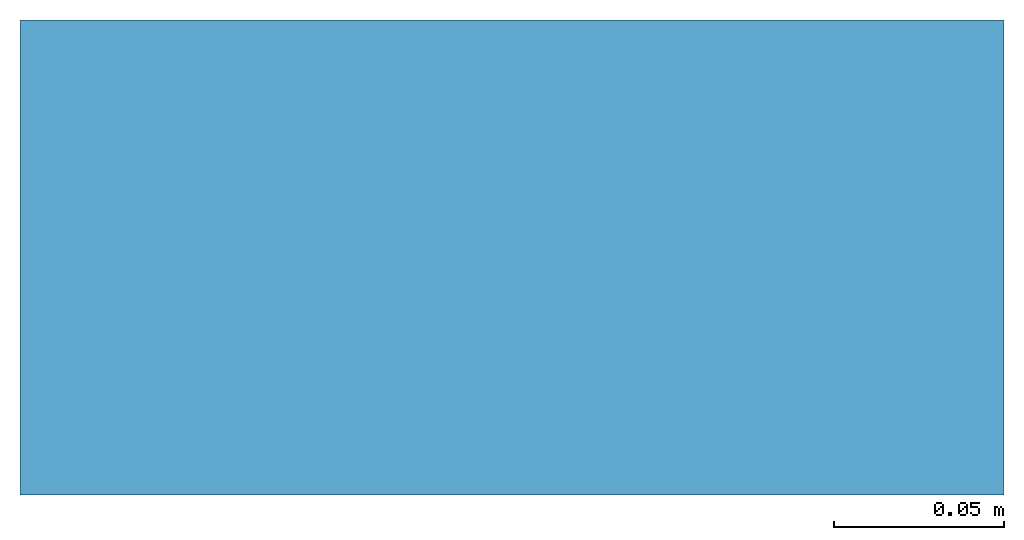
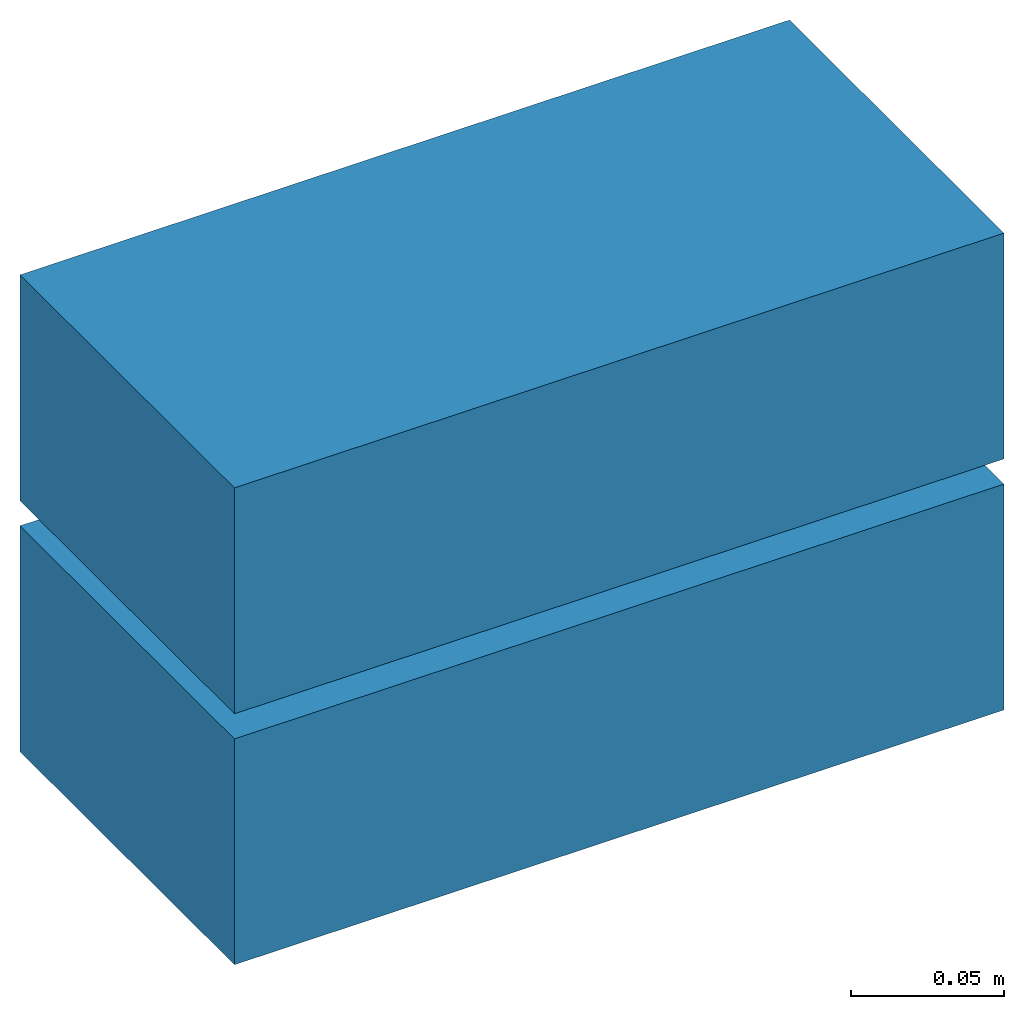
# One storey: 2 beams.
"""IFC4 building model written with IfcOpenShell, lengths in millimetres."""

from ifc_helpers import new_model, entity, si_unit, converted_unit, frame, origin_with_axes, origin_2d_with_axis, place, context, subcontext, project, spatial, polygons, source, transform, mapped, material, type_object, type_shapes, element, save


model = new_model("IFC4")

# Units and contexts
model_context = context("Model", 3, precision=1e-05, world=origin_with_axes())
plan_context = context("Plan", 2, precision=1e-05, world=origin_2d_with_axis())
body_context = subcontext(model_context, "Body", "Model", "MODEL_VIEW")
ifc_project = project(units=[si_unit("VOLUMEUNIT", "CUBIC_METRE"), si_unit("LENGTHUNIT", "METRE", prefix="MILLI"), converted_unit("PLANEANGLEUNIT", "degree", entity("IfcReal", 0.0174532925199433), si_unit("PLANEANGLEUNIT", "RADIAN"), dimensions=[0, 0, 0, 0, 0, 0, 0]), si_unit("AREAUNIT", "SQUARE_METRE")], contexts=[model_context, plan_context])

# Site, building, storey
site_placement = place(None, origin_with_axes())
site = spatial("IfcSite", under=ifc_project, at=site_placement)
building_placement = place(site_placement, origin_with_axes())
building = spatial("IfcBuilding", under=site, at=building_placement, Name="Building")
storey_placement = place(building_placement, origin_with_axes())
storey = spatial("IfcBuildingStorey", under=building, at=storey_placement, Name="Storey")

# Beams
ifc_material = material(Name="Cement Block", Category="Cement")
beam_type = type_object("IfcBeamType", Name="RDP 290x140x90", PredefinedType="USERDEFINED", material=ifc_material)
shared_shape = source(origin_with_axes(), body_context, "Body", "Tessellation", [
    polygons([(0.861823499202728, -0.0736117288470268, 0.359587341547012), (0.861823499202728, -0.0736117288470268, 90.3595581054688), (0.861823499202728, 139.926361083984, 0.359587341547012), (0.861823499202728, 139.926361083984, 90.3595581054688), (290.861755371094, -0.0736117288470268, 0.359587341547012), (290.861755371094, -0.0736117288470268, 90.3595581054688), (290.861755371094, 139.926361083984, 0.359587341547012), (290.861755371094, 139.926361083984, 90.3595581054688)], [[[1, 2, 4, 3]], [[3, 4, 8, 7]], [[7, 8, 6, 5]], [[5, 6, 2, 1]], [[3, 7, 5, 1]], [[8, 4, 2, 6]]], closed=True),
])
type_shapes(beam_type, [shared_shape])
beam_1_placement = place(storey_placement, frame((0.0, 0.0, 99.6404141187668), z_axis=(0.0, 0.0, 1.0), x_axis=(1.0, 0.0, 0.0)))
element("IfcBeam", 1, at=beam_1_placement, inside=storey, type_object=beam_type, Name="290x90x140", context=body_context, shape_type="MappedRepresentation", body=[
    mapped(shared_shape, transform((0.0, 0.0, 0.0), x_axis=(1.0, 0.0, 0.0), y_axis=(0.0, 1.0, 0.0), z_axis=(0.0, 0.0, 1.0), scale=1.0)),
])
beam_2_placement = place(storey_placement, frame((0.0, 0.0, -0.359587371349335), z_axis=(0.0, 0.0, 1.0), x_axis=(1.0, 0.0, 0.0)))
element("IfcBeam", 2, at=beam_2_placement, inside=storey, type_object=beam_type, context=body_context, shape_type="MappedRepresentation", body=[
    mapped(shared_shape, transform((0.0, 0.0, 0.0), x_axis=(1.0, 0.0, 0.0), y_axis=(0.0, 1.0, 0.0), z_axis=(0.0, 0.0, 1.0), scale=1.0)),
])

save(model, "model.ifc")
